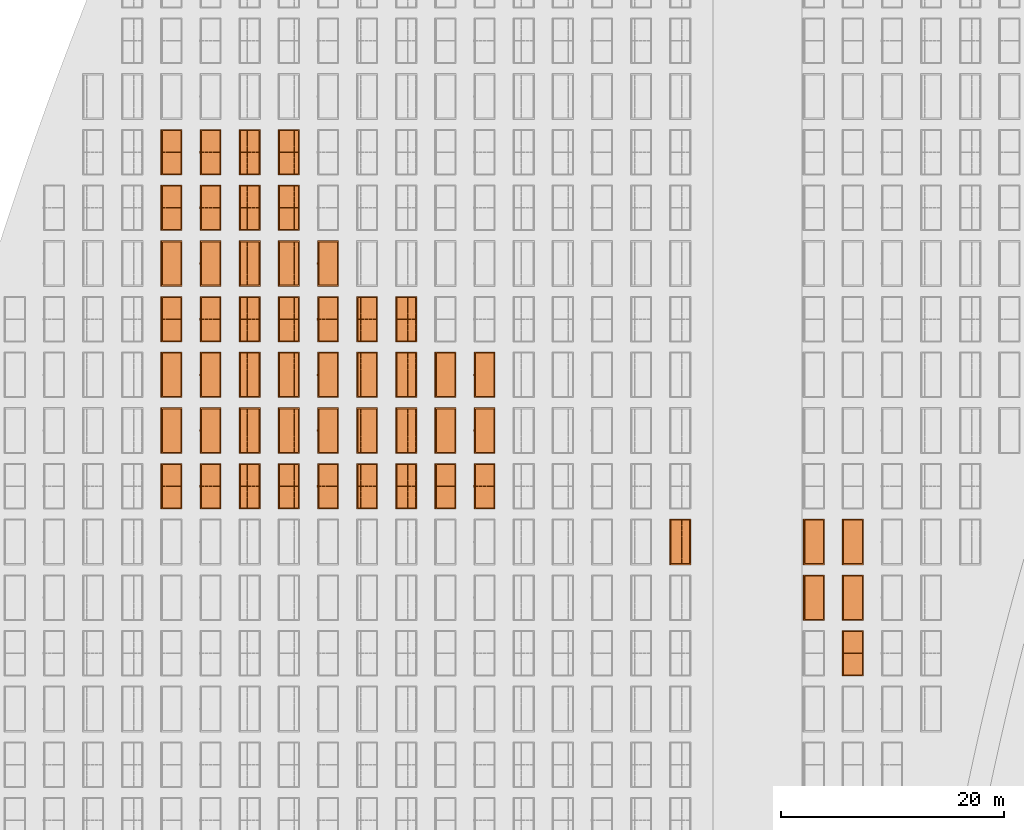
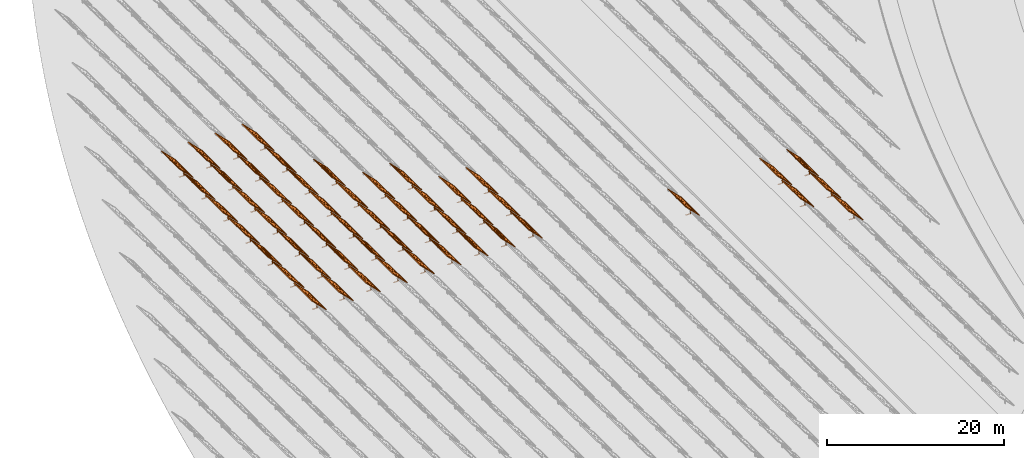
# One storey, part 24 of 39: 53 proxies.
"""IFC2X3 building model written with IfcOpenShell, lengths in millimetres."""

from ifc_helpers import new_model, entity, si_unit, converted_unit, derived_unit, direction, frame, frame_2d, origin, origin_2d_with_axis, place, context, subcontext, project, spatial, polyline, rectangle, outline, extrude, source, transform, mapped, material, material_list, element, save


model = new_model("IFC2X3")

# Units and contexts
model_context = context("Model", 3, precision=1e-06, world=origin(), true_north=direction((2.0, 6.12303176911189e-17, 1.0)))
context_of_model = context(None, 3, precision=1e-06, world=origin(), true_north=direction((2.0, 6.12303176911189e-17, 1.0)))
body_context = subcontext(model_context, "Body", "Model", "MODEL_VIEW")
ifc_project = project(units=[si_unit("LENGTHUNIT", "METRE", prefix="MILLI"), si_unit("AREAUNIT", "SQUARE_METRE", prefix="MILLI"), si_unit("VOLUMEUNIT", "CUBIC_METRE", prefix="MILLI"), converted_unit("PLANEANGLEUNIT", "DEGREE", entity("IfcRatioMeasure", 0.0174532925199433), si_unit("PLANEANGLEUNIT", "RADIAN"), dimensions=[0, 0, 0, 0, 0, 0, 0]), si_unit("MASSUNIT", "GRAM", prefix="KILO"), si_unit("TIMEUNIT", "SECOND"), si_unit("THERMODYNAMICTEMPERATUREUNIT", "KELVIN"), derived_unit("THERMALTRANSMITTANCEUNIT", [(si_unit("MASSUNIT", "GRAM", prefix="KILO"), 1), (si_unit("THERMODYNAMICTEMPERATUREUNIT", "KELVIN"), -1), (si_unit("TIMEUNIT", "SECOND"), -3)]), derived_unit("VOLUMETRICFLOWRATEUNIT", [(si_unit("LENGTHUNIT", "METRE"), 3), (si_unit("TIMEUNIT", "SECOND"), -1)])], contexts=[model_context, context_of_model])

# Site, building, storey
site_placement = place(None, origin())
site = spatial("IfcSite", under=ifc_project, at=site_placement, CompositionType="ELEMENT")
building_placement = place(site_placement, origin())
building = spatial("IfcBuilding", under=site, at=building_placement, CompositionType="ELEMENT")
storey_placement = place(building_placement, frame((0.0, 0.0, 4000.0)))
storey = spatial("IfcBuildingStorey", under=building, at=storey_placement, Name="Level 2", CompositionType="ELEMENT", Elevation=4000.0)

# Proxies
ifc_material_1 = material(Name="Stand-Steel")
ifc_material_2 = material(Name="Aluminium")
ifc_material_3 = material(Name="Glass")
ifc_material_list_1 = material_list([ifc_material_1, ifc_material_2, ifc_material_3])
shared_shape = source(origin(), body_context, "Body", "SweptSolid", [
    extrude(outline(polyline([(-629.526235435404, -220.0), (329.763117717702, -220.0), (329.763117717703, 410.0), (299.763117717703, 410.0), (299.763117717702, -190.0), (-629.526235435404, -190.0), (-629.526235435404, -220.0)])), frame((-190.00003127179, -100.0, 299.763117717707), z_axis=(0.0, 1.0, 0.0), x_axis=(0.0, 0.0, -1.0)), (0.0, 0.0, 1.0), 200.0),
    extrude(rectangle(XDim=20.0000000000001, YDim=200.0, at=frame_2d((0.0, -7.105427357601e-14), x_axis=(0.0, 1.0))), frame((-7.07109908365613, 0.0, 922.21828534124), z_axis=(-0.70710678118654, 0.0, 0.707106781186555), x_axis=(0.0, 1.0, 0.0)), (0.0, 0.0, 1.0), 2600.0),
    extrude(rectangle(XDim=24.9999999999997, YDim=24.9999999999999, at=frame_2d((2.87769807982841e-13, -9.50350909079134e-14), x_axis=(1.0, 0.0))), frame((-1449.56292018118, -1950.0, 2449.57494522722), z_axis=(0.0, 1.0, 0.0), x_axis=(-0.707106781186548, 0.0, -0.707106781186548)), (0.0, 0.0, 1.0), 3900.0),
    extrude(rectangle(XDim=24.9999999999999, YDim=25.0000000000001, at=origin_2d_with_axis()), frame((-1096.0095295879, -1950.0, 2096.02155463395), z_axis=(0.0, 1.0, 0.0), x_axis=(-0.707106781186542, 0.0, -0.707106781186553)), (0.0, 0.0, 1.0), 3900.0),
    extrude(rectangle(XDim=24.9999999999999, YDim=25.0000000000001, at=origin_2d_with_axis()), frame((-742.456138994631, -1950.0, 1742.46816404067), z_axis=(0.0, 1.0, 0.0), x_axis=(-0.707106781186542, 0.0, -0.707106781186553)), (0.0, 0.0, 1.0), 3900.0),
    extrude(rectangle(XDim=25.0, YDim=24.9999999999997, at=frame_2d((-7.19424519957101e-14, 1.19904086659517e-13), x_axis=(1.0, 0.0))), frame((-388.902748401358, -1950.0, 1388.9147734474), z_axis=(0.0, 1.0, 0.0), x_axis=(-0.707106781186545, 0.0, -0.70710678118655)), (0.0, 0.0, 1.0), 3900.0),
    extrude(rectangle(XDim=25.0000000000002, YDim=25.0, at=frame_2d((1.35891298214119e-13, 6.21724893790088e-15), x_axis=(0.0, 1.0))), frame((-35.3553703311048, 1500.0, 1035.35537033109), z_axis=(-0.707106781186544, 0.0, 0.707106781186551), x_axis=(0.0, 1.0, 0.0)), (0.0, 0.0, 1.0), 2440.0),
    extrude(rectangle(XDim=25.0000000000002, YDim=25.0, at=frame_2d((0.0, 1.77635683940025e-15), x_axis=(0.0, 1.0))), frame((-35.3553703311059, 1000.0, 1035.35537033109), z_axis=(-0.707106781186546, 0.0, 0.707106781186549), x_axis=(0.0, 1.0, 0.0)), (0.0, 0.0, 1.0), 2440.0),
    extrude(rectangle(XDim=25.0000000000002, YDim=25.0, at=frame_2d((0.0, 8.43769498715119e-14), x_axis=(0.0, 1.0))), frame((-26.5165355662756, 0.0, 1044.19420509593), z_axis=(-0.707106781186546, 0.0, 0.707106781186549), x_axis=(0.0, -1.0, 0.0)), (0.0, 0.0, 1.0), 2440.0),
    extrude(rectangle(XDim=25.0000000000002, YDim=25.0, at=frame_2d((0.0, 8.88178419700125e-16), x_axis=(0.0, 1.0))), frame((-35.3553703311065, 500.0, 1035.35537033109), z_axis=(-0.707106781186546, 0.0, 0.707106781186549), x_axis=(0.0, 1.0, 0.0)), (0.0, 0.0, 1.0), 2440.0),
    extrude(rectangle(XDim=25.0000000000002, YDim=25.0, at=frame_2d((0.0, 8.88178419700125e-16), x_axis=(0.0, 1.0))), frame((-35.3553703311086, -500.0, 1035.35537033109), z_axis=(-0.707106781186546, 0.0, 0.707106781186549), x_axis=(0.0, 1.0, 0.0)), (0.0, 0.0, 1.0), 2440.0),
    extrude(rectangle(XDim=25.0000000000002, YDim=25.0, at=frame_2d((0.0, 8.88178419700125e-16), x_axis=(0.0, 1.0))), frame((-35.3553703311095, -1000.0, 1035.35537033109), z_axis=(-0.707106781186546, 0.0, 0.707106781186549), x_axis=(0.0, 1.0, 0.0)), (0.0, 0.0, 1.0), 2440.0),
    extrude(rectangle(XDim=25.0000000000002, YDim=25.0, at=frame_2d((1.35891298214119e-13, 1.77635683940025e-15), x_axis=(0.0, 1.0))), frame((-35.3553703311107, -1500.0, 1035.35537033109), z_axis=(-0.707106781186546, 0.0, 0.707106781186549), x_axis=(0.0, 1.0, 0.0)), (0.0, 0.0, 1.0), 2440.0),
    extrude(rectangle(XDim=2400.0, YDim=11.9999999999994, at=frame_2d((-1.13686837721616e-13, 2.02948768901479e-13), x_axis=(1.0, 0.0))), frame((-883.883507754966, -1950.0, 1883.88350775495), z_axis=(0.0, 1.0, 0.0), x_axis=(0.707106781186546, 0.0, -0.707106781186549)), (0.0, 0.0, 1.0), 3900.0),
    extrude(outline(polyline([(-2050.0, -1300.0), (2050.0, -1300.0), (2050.0, 1300.0), (-2050.0, 1300.0), (-2050.0, -1300.0)]), holes=[polyline([(1950.0, -1200.0), (-1950.0, -1200.0), (-1950.0, 1200.0), (1950.0, 1200.0), (1950.0, -1200.0)])]), frame((-919.238846814293, 0.0, 1848.52816869563), z_axis=(0.707106781186554, 0.0, 0.707106781186541), x_axis=(0.0, 1.0, 0.0)), (0.0, 0.0, 1.0), 99.9999999999898),
])
proxy_1_placement = place(storey_placement, frame((-144385.32831183, 515144.680552409, 30.0)))
element("IfcBuildingElementProxy", 1, at=proxy_1_placement, inside=storey, material=ifc_material_list_1, Name="Solar Panel_4000X2500:Solar Panel_4000X2500", ObjectType="Solar Panel_4000X2500", CompositionType="ELEMENT", context=body_context, shape_type="MappedRepresentation", body=[
    mapped(shared_shape, transform((0.0, 0.0, 0.0), scale=1.0)),
])
ifc_material_list_2 = material_list([ifc_material_1, ifc_material_2, ifc_material_3])
proxy_2_placement = place(storey_placement, frame((-144385.32831183, 520144.680552409, 30.0)))
element("IfcBuildingElementProxy", 2, at=proxy_2_placement, inside=storey, material=ifc_material_list_2, Name="Solar Panel_4000X2500:Solar Panel_4000X2500", ObjectType="Solar Panel_4000X2500", CompositionType="ELEMENT", context=body_context, shape_type="MappedRepresentation", body=[
    mapped(shared_shape, transform((0.0, 0.0, 0.0), scale=1.0)),
])
ifc_material_list_3 = material_list([ifc_material_1, ifc_material_2, ifc_material_3])
proxy_3_placement = place(storey_placement, frame((-144385.32831183, 525144.680552409, 30.0)))
element("IfcBuildingElementProxy", 3, at=proxy_3_placement, inside=storey, material=ifc_material_list_3, Name="Solar Panel_4000X2500:Solar Panel_4000X2500", ObjectType="Solar Panel_4000X2500", CompositionType="ELEMENT", context=body_context, shape_type="MappedRepresentation", body=[
    mapped(shared_shape, transform((0.0, 0.0, 0.0), scale=1.0)),
])
ifc_material_list_4 = material_list([ifc_material_1, ifc_material_2, ifc_material_3])
proxy_4_placement = place(storey_placement, frame((-147885.32831183, 520144.680552409, 30.0)))
element("IfcBuildingElementProxy", 4, at=proxy_4_placement, inside=storey, material=ifc_material_list_4, Name="Solar Panel_4000X2500:Solar Panel_4000X2500", ObjectType="Solar Panel_4000X2500", CompositionType="ELEMENT", context=body_context, shape_type="MappedRepresentation", body=[
    mapped(shared_shape, transform((0.0, 0.0, 0.0), scale=1.0)),
])
ifc_material_list_5 = material_list([ifc_material_1, ifc_material_2, ifc_material_3])
proxy_5_placement = place(storey_placement, frame((-147885.32831183, 525144.680552409, 30.0)))
element("IfcBuildingElementProxy", 5, at=proxy_5_placement, inside=storey, material=ifc_material_list_5, Name="Solar Panel_4000X2500:Solar Panel_4000X2500", ObjectType="Solar Panel_4000X2500", CompositionType="ELEMENT", context=body_context, shape_type="MappedRepresentation", body=[
    mapped(shared_shape, transform((0.0, 0.0, 0.0), scale=1.0)),
])
ifc_material_list_6 = material_list([ifc_material_1, ifc_material_2, ifc_material_3])
proxy_6_placement = place(storey_placement, frame((-159885.32831183, 525144.680552409, 30.0)))
element("IfcBuildingElementProxy", 6, at=proxy_6_placement, inside=storey, material=ifc_material_list_6, Name="Solar Panel_4000X2500:Solar Panel_4000X2500", ObjectType="Solar Panel_4000X2500", CompositionType="ELEMENT", context=body_context, shape_type="MappedRepresentation", body=[
    mapped(shared_shape, transform((0.0, 0.0, 0.0), scale=1.0)),
])
ifc_material_list_7 = material_list([ifc_material_1, ifc_material_2, ifc_material_3])
proxy_7_placement = place(storey_placement, frame((-177460.32831183, 530144.680552408, 30.0)))
element("IfcBuildingElementProxy", 7, at=proxy_7_placement, inside=storey, material=ifc_material_list_7, Name="Solar Panel_4000X2500:Solar Panel_4000X2500", ObjectType="Solar Panel_4000X2500", CompositionType="ELEMENT", context=body_context, shape_type="MappedRepresentation", body=[
    mapped(shared_shape, transform((0.0, 0.0, 0.0), scale=1.0)),
])
ifc_material_list_8 = material_list([ifc_material_1, ifc_material_2, ifc_material_3])
proxy_8_placement = place(storey_placement, frame((-177460.32831183, 535144.680552408, 30.0)))
element("IfcBuildingElementProxy", 8, at=proxy_8_placement, inside=storey, material=ifc_material_list_8, Name="Solar Panel_4000X2500:Solar Panel_4000X2500", ObjectType="Solar Panel_4000X2500", CompositionType="ELEMENT", context=body_context, shape_type="MappedRepresentation", body=[
    mapped(shared_shape, transform((0.0, 0.0, 0.0), scale=1.0)),
])
ifc_material_list_9 = material_list([ifc_material_1, ifc_material_2, ifc_material_3])
proxy_9_placement = place(storey_placement, frame((-177460.32831183, 540144.680552408, 30.0)))
element("IfcBuildingElementProxy", 9, at=proxy_9_placement, inside=storey, material=ifc_material_list_9, Name="Solar Panel_4000X2500:Solar Panel_4000X2500", ObjectType="Solar Panel_4000X2500", CompositionType="ELEMENT", context=body_context, shape_type="MappedRepresentation", body=[
    mapped(shared_shape, transform((0.0, 0.0, 0.0), scale=1.0)),
])
ifc_material_list_10 = material_list([ifc_material_1, ifc_material_2, ifc_material_3])
proxy_10_placement = place(storey_placement, frame((-180975.32831183, 530144.680552408, 30.0)))
element("IfcBuildingElementProxy", 10, at=proxy_10_placement, inside=storey, material=ifc_material_list_10, Name="Solar Panel_4000X2500:Solar Panel_4000X2500", ObjectType="Solar Panel_4000X2500", CompositionType="ELEMENT", context=body_context, shape_type="MappedRepresentation", body=[
    mapped(shared_shape, transform((0.0, 0.0, 0.0), scale=1.0)),
])
ifc_material_list_11 = material_list([ifc_material_1, ifc_material_2, ifc_material_3])
proxy_11_placement = place(storey_placement, frame((-180975.32831183, 535144.680552408, 30.0)))
element("IfcBuildingElementProxy", 11, at=proxy_11_placement, inside=storey, material=ifc_material_list_11, Name="Solar Panel_4000X2500:Solar Panel_4000X2500", ObjectType="Solar Panel_4000X2500", CompositionType="ELEMENT", context=body_context, shape_type="MappedRepresentation", body=[
    mapped(shared_shape, transform((0.0, 0.0, 0.0), scale=1.0)),
])
ifc_material_list_12 = material_list([ifc_material_1, ifc_material_2, ifc_material_3])
proxy_12_placement = place(storey_placement, frame((-180975.32831183, 540144.680552408, 30.0)))
element("IfcBuildingElementProxy", 12, at=proxy_12_placement, inside=storey, material=ifc_material_list_12, Name="Solar Panel_4000X2500:Solar Panel_4000X2500", ObjectType="Solar Panel_4000X2500", CompositionType="ELEMENT", context=body_context, shape_type="MappedRepresentation", body=[
    mapped(shared_shape, transform((0.0, 0.0, 0.0), scale=1.0)),
])
ifc_material_list_13 = material_list([ifc_material_1, ifc_material_2, ifc_material_3])
proxy_13_placement = place(storey_placement, frame((-184490.32831183, 530144.680552408, 30.0)))
element("IfcBuildingElementProxy", 13, at=proxy_13_placement, inside=storey, material=ifc_material_list_13, Name="Solar Panel_4000X2500:Solar Panel_4000X2500", ObjectType="Solar Panel_4000X2500", CompositionType="ELEMENT", context=body_context, shape_type="MappedRepresentation", body=[
    mapped(shared_shape, transform((0.0, 0.0, 0.0), scale=1.0)),
])
ifc_material_list_14 = material_list([ifc_material_1, ifc_material_2, ifc_material_3])
proxy_14_placement = place(storey_placement, frame((-184490.32831183, 535144.680552408, 30.0)))
element("IfcBuildingElementProxy", 14, at=proxy_14_placement, inside=storey, material=ifc_material_list_14, Name="Solar Panel_4000X2500:Solar Panel_4000X2500", ObjectType="Solar Panel_4000X2500", CompositionType="ELEMENT", context=body_context, shape_type="MappedRepresentation", body=[
    mapped(shared_shape, transform((0.0, 0.0, 0.0), scale=1.0)),
])
ifc_material_list_15 = material_list([ifc_material_1, ifc_material_2, ifc_material_3])
proxy_15_placement = place(storey_placement, frame((-184490.32831183, 540144.680552408, 30.0)))
element("IfcBuildingElementProxy", 15, at=proxy_15_placement, inside=storey, material=ifc_material_list_15, Name="Solar Panel_4000X2500:Solar Panel_4000X2500", ObjectType="Solar Panel_4000X2500", CompositionType="ELEMENT", context=body_context, shape_type="MappedRepresentation", body=[
    mapped(shared_shape, transform((0.0, 0.0, 0.0), scale=1.0)),
])
ifc_material_list_16 = material_list([ifc_material_1, ifc_material_2, ifc_material_3])
proxy_16_placement = place(storey_placement, frame((-184490.32831183, 545144.680552408, 30.0)))
element("IfcBuildingElementProxy", 16, at=proxy_16_placement, inside=storey, material=ifc_material_list_16, Name="Solar Panel_4000X2500:Solar Panel_4000X2500", ObjectType="Solar Panel_4000X2500", CompositionType="ELEMENT", context=body_context, shape_type="MappedRepresentation", body=[
    mapped(shared_shape, transform((0.0, 0.0, 0.0), scale=1.0)),
])
ifc_material_list_17 = material_list([ifc_material_1, ifc_material_2, ifc_material_3])
proxy_17_placement = place(storey_placement, frame((-188005.32831183, 530144.680552408, 30.0)))
element("IfcBuildingElementProxy", 17, at=proxy_17_placement, inside=storey, material=ifc_material_list_17, Name="Solar Panel_4000X2500:Solar Panel_4000X2500", ObjectType="Solar Panel_4000X2500", CompositionType="ELEMENT", context=body_context, shape_type="MappedRepresentation", body=[
    mapped(shared_shape, transform((0.0, 0.0, 0.0), scale=1.0)),
])
ifc_material_list_18 = material_list([ifc_material_1, ifc_material_2, ifc_material_3])
proxy_18_placement = place(storey_placement, frame((-188005.32831183, 535144.680552408, 30.0)))
element("IfcBuildingElementProxy", 18, at=proxy_18_placement, inside=storey, material=ifc_material_list_18, Name="Solar Panel_4000X2500:Solar Panel_4000X2500", ObjectType="Solar Panel_4000X2500", CompositionType="ELEMENT", context=body_context, shape_type="MappedRepresentation", body=[
    mapped(shared_shape, transform((0.0, 0.0, 0.0), scale=1.0)),
])
ifc_material_list_19 = material_list([ifc_material_1, ifc_material_2, ifc_material_3])
proxy_19_placement = place(storey_placement, frame((-188005.32831183, 540144.680552408, 30.0)))
element("IfcBuildingElementProxy", 19, at=proxy_19_placement, inside=storey, material=ifc_material_list_19, Name="Solar Panel_4000X2500:Solar Panel_4000X2500", ObjectType="Solar Panel_4000X2500", CompositionType="ELEMENT", context=body_context, shape_type="MappedRepresentation", body=[
    mapped(shared_shape, transform((0.0, 0.0, 0.0), scale=1.0)),
])
ifc_material_list_20 = material_list([ifc_material_1, ifc_material_2, ifc_material_3])
proxy_20_placement = place(storey_placement, frame((-188005.32831183, 545144.680552408, 30.0)))
element("IfcBuildingElementProxy", 20, at=proxy_20_placement, inside=storey, material=ifc_material_list_20, Name="Solar Panel_4000X2500:Solar Panel_4000X2500", ObjectType="Solar Panel_4000X2500", CompositionType="ELEMENT", context=body_context, shape_type="MappedRepresentation", body=[
    mapped(shared_shape, transform((0.0, 0.0, 0.0), scale=1.0)),
])
ifc_material_list_21 = material_list([ifc_material_1, ifc_material_2, ifc_material_3])
proxy_21_placement = place(storey_placement, frame((-191520.32831183, 530144.680552408, 30.0)))
element("IfcBuildingElementProxy", 21, at=proxy_21_placement, inside=storey, material=ifc_material_list_21, Name="Solar Panel_4000X2500:Solar Panel_4000X2500", ObjectType="Solar Panel_4000X2500", CompositionType="ELEMENT", context=body_context, shape_type="MappedRepresentation", body=[
    mapped(shared_shape, transform((0.0, 0.0, 0.0), scale=1.0)),
])
ifc_material_list_22 = material_list([ifc_material_1, ifc_material_2, ifc_material_3])
proxy_22_placement = place(storey_placement, frame((-191520.32831183, 535144.680552408, 30.0)))
element("IfcBuildingElementProxy", 22, at=proxy_22_placement, inside=storey, material=ifc_material_list_22, Name="Solar Panel_4000X2500:Solar Panel_4000X2500", ObjectType="Solar Panel_4000X2500", CompositionType="ELEMENT", context=body_context, shape_type="MappedRepresentation", body=[
    mapped(shared_shape, transform((0.0, 0.0, 0.0), scale=1.0)),
])
ifc_material_list_23 = material_list([ifc_material_1, ifc_material_2, ifc_material_3])
proxy_23_placement = place(storey_placement, frame((-191520.32831183, 540144.680552408, 30.0)))
element("IfcBuildingElementProxy", 23, at=proxy_23_placement, inside=storey, material=ifc_material_list_23, Name="Solar Panel_4000X2500:Solar Panel_4000X2500", ObjectType="Solar Panel_4000X2500", CompositionType="ELEMENT", context=body_context, shape_type="MappedRepresentation", body=[
    mapped(shared_shape, transform((0.0, 0.0, 0.0), scale=1.0)),
])
ifc_material_list_24 = material_list([ifc_material_1, ifc_material_2, ifc_material_3])
proxy_24_placement = place(storey_placement, frame((-191520.32831183, 545144.680552408, 30.0)))
element("IfcBuildingElementProxy", 24, at=proxy_24_placement, inside=storey, material=ifc_material_list_24, Name="Solar Panel_4000X2500:Solar Panel_4000X2500", ObjectType="Solar Panel_4000X2500", CompositionType="ELEMENT", context=body_context, shape_type="MappedRepresentation", body=[
    mapped(shared_shape, transform((0.0, 0.0, 0.0), scale=1.0)),
])
ifc_material_list_25 = material_list([ifc_material_1, ifc_material_2, ifc_material_3])
proxy_25_placement = place(storey_placement, frame((-191520.32831183, 550144.680552408, 30.0)))
element("IfcBuildingElementProxy", 25, at=proxy_25_placement, inside=storey, material=ifc_material_list_25, Name="Solar Panel_4000X2500:Solar Panel_4000X2500", ObjectType="Solar Panel_4000X2500", CompositionType="ELEMENT", context=body_context, shape_type="MappedRepresentation", body=[
    mapped(shared_shape, transform((0.0, 0.0, 0.0), scale=1.0)),
])
ifc_material_list_26 = material_list([ifc_material_1, ifc_material_2, ifc_material_3])
proxy_26_placement = place(storey_placement, frame((-195035.32831183, 530144.680552408, 30.0)))
element("IfcBuildingElementProxy", 26, at=proxy_26_placement, inside=storey, material=ifc_material_list_26, Name="Solar Panel_4000X2500:Solar Panel_4000X2500", ObjectType="Solar Panel_4000X2500", CompositionType="ELEMENT", context=body_context, shape_type="MappedRepresentation", body=[
    mapped(shared_shape, transform((0.0, 0.0, 0.0), scale=1.0)),
])
ifc_material_list_27 = material_list([ifc_material_1, ifc_material_2, ifc_material_3])
proxy_27_placement = place(storey_placement, frame((-195035.32831183, 535144.680552408, 30.0)))
element("IfcBuildingElementProxy", 27, at=proxy_27_placement, inside=storey, material=ifc_material_list_27, Name="Solar Panel_4000X2500:Solar Panel_4000X2500", ObjectType="Solar Panel_4000X2500", CompositionType="ELEMENT", context=body_context, shape_type="MappedRepresentation", body=[
    mapped(shared_shape, transform((0.0, 0.0, 0.0), scale=1.0)),
])
ifc_material_list_28 = material_list([ifc_material_1, ifc_material_2, ifc_material_3])
proxy_28_placement = place(storey_placement, frame((-195035.32831183, 540144.680552408, 30.0)))
element("IfcBuildingElementProxy", 28, at=proxy_28_placement, inside=storey, material=ifc_material_list_28, Name="Solar Panel_4000X2500:Solar Panel_4000X2500", ObjectType="Solar Panel_4000X2500", CompositionType="ELEMENT", context=body_context, shape_type="MappedRepresentation", body=[
    mapped(shared_shape, transform((0.0, 0.0, 0.0), scale=1.0)),
])
ifc_material_list_29 = material_list([ifc_material_1, ifc_material_2, ifc_material_3])
proxy_29_placement = place(storey_placement, frame((-195035.32831183, 545144.680552408, 30.0)))
element("IfcBuildingElementProxy", 29, at=proxy_29_placement, inside=storey, material=ifc_material_list_29, Name="Solar Panel_4000X2500:Solar Panel_4000X2500", ObjectType="Solar Panel_4000X2500", CompositionType="ELEMENT", context=body_context, shape_type="MappedRepresentation", body=[
    mapped(shared_shape, transform((0.0, 0.0, 0.0), scale=1.0)),
])
ifc_material_list_30 = material_list([ifc_material_1, ifc_material_2, ifc_material_3])
proxy_30_placement = place(storey_placement, frame((-195035.32831183, 550144.680552408, 30.0)))
element("IfcBuildingElementProxy", 30, at=proxy_30_placement, inside=storey, material=ifc_material_list_30, Name="Solar Panel_4000X2500:Solar Panel_4000X2500", ObjectType="Solar Panel_4000X2500", CompositionType="ELEMENT", context=body_context, shape_type="MappedRepresentation", body=[
    mapped(shared_shape, transform((0.0, 0.0, 0.0), scale=1.0)),
])
ifc_material_list_31 = material_list([ifc_material_1, ifc_material_2, ifc_material_3])
proxy_31_placement = place(storey_placement, frame((-195035.32831183, 555144.680552408, 30.0)))
element("IfcBuildingElementProxy", 31, at=proxy_31_placement, inside=storey, material=ifc_material_list_31, Name="Solar Panel_4000X2500:Solar Panel_4000X2500", ObjectType="Solar Panel_4000X2500", CompositionType="ELEMENT", context=body_context, shape_type="MappedRepresentation", body=[
    mapped(shared_shape, transform((0.0, 0.0, 0.0), scale=1.0)),
])
ifc_material_list_32 = material_list([ifc_material_1, ifc_material_2, ifc_material_3])
proxy_32_placement = place(storey_placement, frame((-195035.32831183, 560144.680552408, 30.0)))
element("IfcBuildingElementProxy", 32, at=proxy_32_placement, inside=storey, material=ifc_material_list_32, Name="Solar Panel_4000X2500:Solar Panel_4000X2500", ObjectType="Solar Panel_4000X2500", CompositionType="ELEMENT", context=body_context, shape_type="MappedRepresentation", body=[
    mapped(shared_shape, transform((0.0, 0.0, 0.0), scale=1.0)),
])
ifc_material_list_33 = material_list([ifc_material_1, ifc_material_2, ifc_material_3])
proxy_33_placement = place(storey_placement, frame((-198550.32831183, 530144.680552409, 30.0)))
element("IfcBuildingElementProxy", 33, at=proxy_33_placement, inside=storey, material=ifc_material_list_33, Name="Solar Panel_4000X2500:Solar Panel_4000X2500", ObjectType="Solar Panel_4000X2500", CompositionType="ELEMENT", context=body_context, shape_type="MappedRepresentation", body=[
    mapped(shared_shape, transform((0.0, 0.0, 0.0), scale=1.0)),
])
ifc_material_list_34 = material_list([ifc_material_1, ifc_material_2, ifc_material_3])
proxy_34_placement = place(storey_placement, frame((-198550.32831183, 535144.680552409, 30.0)))
element("IfcBuildingElementProxy", 34, at=proxy_34_placement, inside=storey, material=ifc_material_list_34, Name="Solar Panel_4000X2500:Solar Panel_4000X2500", ObjectType="Solar Panel_4000X2500", CompositionType="ELEMENT", context=body_context, shape_type="MappedRepresentation", body=[
    mapped(shared_shape, transform((0.0, 0.0, 0.0), scale=1.0)),
])
ifc_material_list_35 = material_list([ifc_material_1, ifc_material_2, ifc_material_3])
proxy_35_placement = place(storey_placement, frame((-198550.32831183, 540144.680552409, 30.0)))
element("IfcBuildingElementProxy", 35, at=proxy_35_placement, inside=storey, material=ifc_material_list_35, Name="Solar Panel_4000X2500:Solar Panel_4000X2500", ObjectType="Solar Panel_4000X2500", CompositionType="ELEMENT", context=body_context, shape_type="MappedRepresentation", body=[
    mapped(shared_shape, transform((0.0, 0.0, 0.0), scale=1.0)),
])
ifc_material_list_36 = material_list([ifc_material_1, ifc_material_2, ifc_material_3])
proxy_36_placement = place(storey_placement, frame((-198550.32831183, 545144.680552408, 30.0)))
element("IfcBuildingElementProxy", 36, at=proxy_36_placement, inside=storey, material=ifc_material_list_36, Name="Solar Panel_4000X2500:Solar Panel_4000X2500", ObjectType="Solar Panel_4000X2500", CompositionType="ELEMENT", context=body_context, shape_type="MappedRepresentation", body=[
    mapped(shared_shape, transform((0.0, 0.0, 0.0), scale=1.0)),
])
ifc_material_list_37 = material_list([ifc_material_1, ifc_material_2, ifc_material_3])
proxy_37_placement = place(storey_placement, frame((-198550.32831183, 550144.680552408, 30.0)))
element("IfcBuildingElementProxy", 37, at=proxy_37_placement, inside=storey, material=ifc_material_list_37, Name="Solar Panel_4000X2500:Solar Panel_4000X2500", ObjectType="Solar Panel_4000X2500", CompositionType="ELEMENT", context=body_context, shape_type="MappedRepresentation", body=[
    mapped(shared_shape, transform((0.0, 0.0, 0.0), scale=1.0)),
])
ifc_material_list_38 = material_list([ifc_material_1, ifc_material_2, ifc_material_3])
proxy_38_placement = place(storey_placement, frame((-198550.32831183, 555144.680552408, 30.0)))
element("IfcBuildingElementProxy", 38, at=proxy_38_placement, inside=storey, material=ifc_material_list_38, Name="Solar Panel_4000X2500:Solar Panel_4000X2500", ObjectType="Solar Panel_4000X2500", CompositionType="ELEMENT", context=body_context, shape_type="MappedRepresentation", body=[
    mapped(shared_shape, transform((0.0, 0.0, 0.0), scale=1.0)),
])
ifc_material_list_39 = material_list([ifc_material_1, ifc_material_2, ifc_material_3])
proxy_39_placement = place(storey_placement, frame((-198550.32831183, 560144.680552408, 30.0)))
element("IfcBuildingElementProxy", 39, at=proxy_39_placement, inside=storey, material=ifc_material_list_39, Name="Solar Panel_4000X2500:Solar Panel_4000X2500", ObjectType="Solar Panel_4000X2500", CompositionType="ELEMENT", context=body_context, shape_type="MappedRepresentation", body=[
    mapped(shared_shape, transform((0.0, 0.0, 0.0), scale=1.0)),
])
ifc_material_list_40 = material_list([ifc_material_1, ifc_material_2, ifc_material_3])
proxy_40_placement = place(storey_placement, frame((-202065.32831183, 530144.680552409, 30.0)))
element("IfcBuildingElementProxy", 40, at=proxy_40_placement, inside=storey, material=ifc_material_list_40, Name="Solar Panel_4000X2500:Solar Panel_4000X2500", ObjectType="Solar Panel_4000X2500", CompositionType="ELEMENT", context=body_context, shape_type="MappedRepresentation", body=[
    mapped(shared_shape, transform((0.0, 0.0, 0.0), scale=1.0)),
])
ifc_material_list_41 = material_list([ifc_material_1, ifc_material_2, ifc_material_3])
proxy_41_placement = place(storey_placement, frame((-202065.32831183, 535144.680552409, 30.0)))
element("IfcBuildingElementProxy", 41, at=proxy_41_placement, inside=storey, material=ifc_material_list_41, Name="Solar Panel_4000X2500:Solar Panel_4000X2500", ObjectType="Solar Panel_4000X2500", CompositionType="ELEMENT", context=body_context, shape_type="MappedRepresentation", body=[
    mapped(shared_shape, transform((0.0, 0.0, 0.0), scale=1.0)),
])
ifc_material_list_42 = material_list([ifc_material_1, ifc_material_2, ifc_material_3])
proxy_42_placement = place(storey_placement, frame((-202065.32831183, 540144.680552409, 30.0)))
element("IfcBuildingElementProxy", 42, at=proxy_42_placement, inside=storey, material=ifc_material_list_42, Name="Solar Panel_4000X2500:Solar Panel_4000X2500", ObjectType="Solar Panel_4000X2500", CompositionType="ELEMENT", context=body_context, shape_type="MappedRepresentation", body=[
    mapped(shared_shape, transform((0.0, 0.0, 0.0), scale=1.0)),
])
ifc_material_list_43 = material_list([ifc_material_1, ifc_material_2, ifc_material_3])
proxy_43_placement = place(storey_placement, frame((-202065.32831183, 545144.680552408, 30.0)))
element("IfcBuildingElementProxy", 43, at=proxy_43_placement, inside=storey, material=ifc_material_list_43, Name="Solar Panel_4000X2500:Solar Panel_4000X2500", ObjectType="Solar Panel_4000X2500", CompositionType="ELEMENT", context=body_context, shape_type="MappedRepresentation", body=[
    mapped(shared_shape, transform((0.0, 0.0, 0.0), scale=1.0)),
])
ifc_material_list_44 = material_list([ifc_material_1, ifc_material_2, ifc_material_3])
proxy_44_placement = place(storey_placement, frame((-202065.32831183, 550144.680552408, 30.0)))
element("IfcBuildingElementProxy", 44, at=proxy_44_placement, inside=storey, material=ifc_material_list_44, Name="Solar Panel_4000X2500:Solar Panel_4000X2500", ObjectType="Solar Panel_4000X2500", CompositionType="ELEMENT", context=body_context, shape_type="MappedRepresentation", body=[
    mapped(shared_shape, transform((0.0, 0.0, 0.0), scale=1.0)),
])
ifc_material_list_45 = material_list([ifc_material_1, ifc_material_2, ifc_material_3])
proxy_45_placement = place(storey_placement, frame((-202065.32831183, 555144.680552408, 30.0)))
element("IfcBuildingElementProxy", 45, at=proxy_45_placement, inside=storey, material=ifc_material_list_45, Name="Solar Panel_4000X2500:Solar Panel_4000X2500", ObjectType="Solar Panel_4000X2500", CompositionType="ELEMENT", context=body_context, shape_type="MappedRepresentation", body=[
    mapped(shared_shape, transform((0.0, 0.0, 0.0), scale=1.0)),
])
ifc_material_list_46 = material_list([ifc_material_1, ifc_material_2, ifc_material_3])
proxy_46_placement = place(storey_placement, frame((-202065.32831183, 560144.680552408, 30.0)))
element("IfcBuildingElementProxy", 46, at=proxy_46_placement, inside=storey, material=ifc_material_list_46, Name="Solar Panel_4000X2500:Solar Panel_4000X2500", ObjectType="Solar Panel_4000X2500", CompositionType="ELEMENT", context=body_context, shape_type="MappedRepresentation", body=[
    mapped(shared_shape, transform((0.0, 0.0, 0.0), scale=1.0)),
])
ifc_material_list_47 = material_list([ifc_material_1, ifc_material_2, ifc_material_3])
proxy_47_placement = place(storey_placement, frame((-205580.32831183, 530144.680552409, 30.0)))
element("IfcBuildingElementProxy", 47, at=proxy_47_placement, inside=storey, material=ifc_material_list_47, Name="Solar Panel_4000X2500:Solar Panel_4000X2500", ObjectType="Solar Panel_4000X2500", CompositionType="ELEMENT", context=body_context, shape_type="MappedRepresentation", body=[
    mapped(shared_shape, transform((0.0, 0.0, 0.0), scale=1.0)),
])
ifc_material_list_48 = material_list([ifc_material_1, ifc_material_2, ifc_material_3])
proxy_48_placement = place(storey_placement, frame((-205580.32831183, 535144.680552409, 30.0)))
element("IfcBuildingElementProxy", 48, at=proxy_48_placement, inside=storey, material=ifc_material_list_48, Name="Solar Panel_4000X2500:Solar Panel_4000X2500", ObjectType="Solar Panel_4000X2500", CompositionType="ELEMENT", context=body_context, shape_type="MappedRepresentation", body=[
    mapped(shared_shape, transform((0.0, 0.0, 0.0), scale=1.0)),
])
ifc_material_list_49 = material_list([ifc_material_1, ifc_material_2, ifc_material_3])
proxy_49_placement = place(storey_placement, frame((-205580.32831183, 540144.680552409, 30.0)))
element("IfcBuildingElementProxy", 49, at=proxy_49_placement, inside=storey, material=ifc_material_list_49, Name="Solar Panel_4000X2500:Solar Panel_4000X2500", ObjectType="Solar Panel_4000X2500", CompositionType="ELEMENT", context=body_context, shape_type="MappedRepresentation", body=[
    mapped(shared_shape, transform((0.0, 0.0, 0.0), scale=1.0)),
])
ifc_material_list_50 = material_list([ifc_material_1, ifc_material_2, ifc_material_3])
proxy_50_placement = place(storey_placement, frame((-205580.32831183, 545144.680552408, 30.0)))
element("IfcBuildingElementProxy", 50, at=proxy_50_placement, inside=storey, material=ifc_material_list_50, Name="Solar Panel_4000X2500:Solar Panel_4000X2500", ObjectType="Solar Panel_4000X2500", CompositionType="ELEMENT", context=body_context, shape_type="MappedRepresentation", body=[
    mapped(shared_shape, transform((0.0, 0.0, 0.0), scale=1.0)),
])
ifc_material_list_51 = material_list([ifc_material_1, ifc_material_2, ifc_material_3])
proxy_51_placement = place(storey_placement, frame((-205580.32831183, 550144.680552408, 30.0)))
element("IfcBuildingElementProxy", 51, at=proxy_51_placement, inside=storey, material=ifc_material_list_51, Name="Solar Panel_4000X2500:Solar Panel_4000X2500", ObjectType="Solar Panel_4000X2500", CompositionType="ELEMENT", context=body_context, shape_type="MappedRepresentation", body=[
    mapped(shared_shape, transform((0.0, 0.0, 0.0), scale=1.0)),
])
ifc_material_list_52 = material_list([ifc_material_1, ifc_material_2, ifc_material_3])
proxy_52_placement = place(storey_placement, frame((-205580.32831183, 555144.680552408, 30.0)))
element("IfcBuildingElementProxy", 52, at=proxy_52_placement, inside=storey, material=ifc_material_list_52, Name="Solar Panel_4000X2500:Solar Panel_4000X2500", ObjectType="Solar Panel_4000X2500", CompositionType="ELEMENT", context=body_context, shape_type="MappedRepresentation", body=[
    mapped(shared_shape, transform((0.0, 0.0, 0.0), scale=1.0)),
])
ifc_material_list_53 = material_list([ifc_material_1, ifc_material_2, ifc_material_3])
proxy_53_placement = place(storey_placement, frame((-205580.32831183, 560144.680552408, 30.0)))
element("IfcBuildingElementProxy", 53, at=proxy_53_placement, inside=storey, material=ifc_material_list_53, Name="Solar Panel_4000X2500:Solar Panel_4000X2500", ObjectType="Solar Panel_4000X2500", CompositionType="ELEMENT", context=body_context, shape_type="MappedRepresentation", body=[
    mapped(shared_shape, transform((0.0, 0.0, 0.0), scale=1.0)),
])

save(model, "model.ifc")
